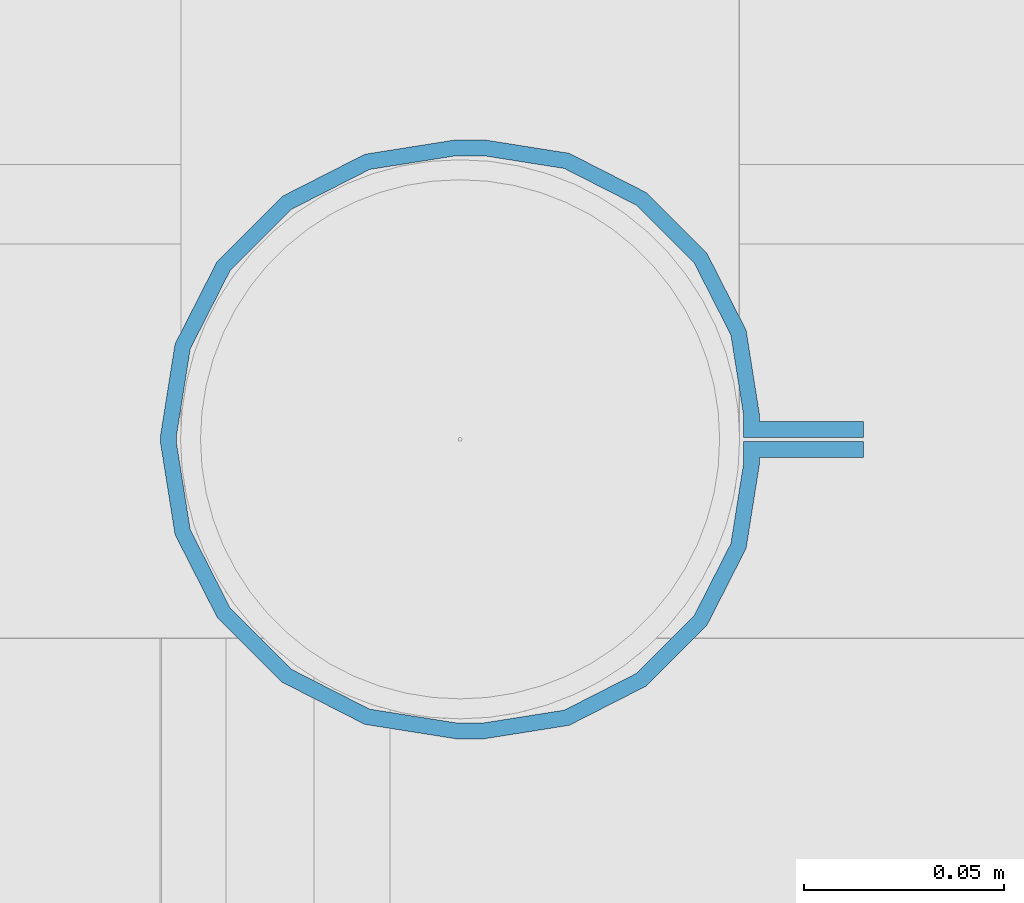
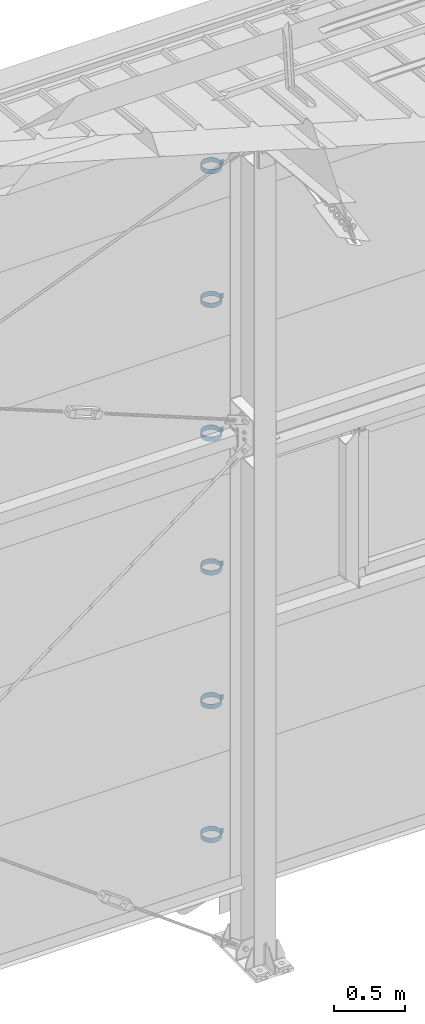
# One storey, part 309 of 709: 6 beams, 6 elements without a shape of their own.
"""IFC4 building model written with IfcOpenShell, lengths in millimetres."""

import ifcopenshell
import ifcopenshell.guid

model = None  # the IFC model being written
_history = None  # IfcOwnerHistory: only IFC2X3 demands one
_inside = {}  # id of a spatial element -> (the spatial element, [elements in it])
_under = {}  # id of a project, library or spatial element -> (it, [spatial elements below it])
_declared = {}  # id of a project -> (the project, [libraries it declares])
_typed = {}  # id of a type object -> (the type object, [elements of that type])
_made_of = {}  # id of a material, layer set ... -> (it, [elements and type objects made of it])


def new_model(schema):
    """Start an empty IFC model of exactly this schema.

    Asked for "IFC4X3", IfcOpenShell would pick the latest addendum, in which some entities
    have other attributes; the version numbers below select the first issue.
    IFC2X3 requires an IfcOwnerHistory on every rooted entity: one is made here for all.
    """
    global model, _history
    if schema == "IFC4X3":
        model = ifcopenshell.file(schema_version=(4, 3, 0, 0))
    else:
        model = ifcopenshell.file(schema=schema)
    _inside.clear()
    _under.clear()
    _declared.clear()
    _typed.clear()
    _made_of.clear()
    _history = None
    if model.schema == "IFC2X3":
        org = make("IfcOrganization", Name="unknown")
        user = make(
            "IfcPersonAndOrganization",
            ThePerson=make("IfcPerson", FamilyName="unknown"),
            TheOrganization=org,
        )
        app = make(
            "IfcApplication",
            ApplicationDeveloper=org,
            Version="unknown",
            ApplicationFullName="unknown",
            ApplicationIdentifier="unknown",
        )
        _history = make(
            "IfcOwnerHistory",
            OwningUser=user,
            OwningApplication=app,
            ChangeAction="ADDED",
            CreationDate=0,
        )
    return model


def make(cls, **values):
    """One entity of the class cls with the attributes given. An attribute that is None is left unset."""
    return model.create_entity(
        cls, **{name: value for name, value in values.items() if value is not None}
    )


def rooted(cls, **values):
    """An entity with a GlobalId (a new one), such as an element, a storey or a relation."""
    return make(cls, GlobalId=ifcopenshell.guid.new(), OwnerHistory=_history, **values)


def si_unit(unit_type, name, prefix=None):
    """IfcSIUnit, for example si_unit("LENGTHUNIT", "METRE", prefix="MILLI")."""
    return make("IfcSIUnit", UnitType=unit_type, Prefix=prefix, Name=name)


def assignment(units):
    """IfcUnitAssignment: the units of a project."""
    return None if units is None else make("IfcUnitAssignment", Units=units)


def point(xyz):
    """IfcCartesianPoint."""
    return None if xyz is None else make("IfcCartesianPoint", Coordinates=xyz)


def direction(xyz):
    """IfcDirection."""
    return None if xyz is None else make("IfcDirection", DirectionRatios=xyz)


def frame(location, z_axis=None, x_axis=None):
    """IfcAxis2Placement3D, a coordinate frame: its origin and axes. An axis left out is left unset."""
    return make(
        "IfcAxis2Placement3D",
        Location=point(location),
        Axis=direction(z_axis),
        RefDirection=direction(x_axis),
    )


def origin_with_axes():
    """The frame at (0, 0, 0) with the z axis (0, 0, 1) and the x axis (1, 0, 0) written out."""
    return frame((0.0, 0.0, 0.0), z_axis=(0.0, 0.0, 1.0), x_axis=(1.0, 0.0, 0.0))


def place(relative_to, where):
    """IfcLocalPlacement: puts the frame where relative to a parent placement (None: the world)."""
    return make(
        "IfcLocalPlacement", PlacementRelTo=relative_to, RelativePlacement=where
    )


def context(
    kind, dimensions, precision=None, world=None, true_north=None, identifier=None
):
    """IfcGeometricRepresentationContext, for example the 3D "Model" context."""
    return make(
        "IfcGeometricRepresentationContext",
        ContextIdentifier=identifier,
        ContextType=kind,
        CoordinateSpaceDimension=dimensions,
        Precision=precision,
        WorldCoordinateSystem=world,
        TrueNorth=true_north,
    )


def subcontext(parent, identifier, kind, view, scale=None):
    """IfcGeometricRepresentationSubContext, for example "Body" below "Model"."""
    return make(
        "IfcGeometricRepresentationSubContext",
        ContextIdentifier=identifier,
        ContextType=kind,
        ParentContext=parent,
        TargetScale=scale,
        TargetView=view,
    )


def project(units=None, contexts=None):
    """IfcProject with its units and contexts."""
    return rooted(
        "IfcProject",
        Name="project",
        RepresentationContexts=contexts,
        UnitsInContext=assignment(units),
    )


def spatial(cls, under=None, at=None, **own):
    """A site, building, storey or space (cls), placed at a placement, below another one or the project."""
    s = rooted(cls, ObjectPlacement=at, **own)
    if under is not None:
        _under.setdefault(under.id(), (under, []))[1].append(s)
    return s


def point_list(points):
    """IfcCartesianPointList2D or 3D."""
    cls = (
        "IfcCartesianPointList2D" if len(points[0]) == 2 else "IfcCartesianPointList3D"
    )
    return make(cls, CoordList=points)


def polygons(points, faces, closed=None, point_numbers=None):
    """IfcPolygonalFaceSet: a face is its outer loop, then its inner loops; points numbered from 1."""
    made = []
    for loops in faces:
        if len(loops) == 1:
            made.append(make("IfcIndexedPolygonalFace", CoordIndex=loops[0]))
        else:
            made.append(
                make(
                    "IfcIndexedPolygonalFaceWithVoids",
                    CoordIndex=loops[0],
                    InnerCoordIndices=loops[1:],
                )
            )
    return make(
        "IfcPolygonalFaceSet",
        Coordinates=point_list(points),
        Closed=closed,
        Faces=made,
        PnIndex=point_numbers,
    )


def shape(context_of_items, identifier, shape_type, items):
    """IfcShapeRepresentation: the items that make up one representation, for example the "Body"."""
    return make(
        "IfcShapeRepresentation",
        ContextOfItems=context_of_items,
        RepresentationIdentifier=identifier,
        RepresentationType=shape_type,
        Items=items,
    )


def material(Name=None, Category=None):
    """IfcMaterial."""
    return make("IfcMaterial", Name=Name, Category=Category)


def made_of(thing, what):
    """Note that an element or type object is made of a material, layer set ...; save() writes the relation."""
    if what is not None:
        _made_of.setdefault(what.id(), (what, []))[1].append(thing)
    return thing


def element(
    cls,
    number,
    at=None,
    inside=None,
    cuts=None,
    type_object=None,
    material=None,
    context=None,
    identifier="Body",
    shape_type=None,
    held_by="IfcProductDefinitionShape",
    body=None,
    shapes=None,
    **own,
):
    """One element of the class cls, such as IfcWall. Its Tag is "e" and its number.

    at: its placement. inside: the storey or other place that contains it. cuts: it is an
    opening in that element (IfcRelVoidsElement). A single representation is given by context,
    identifier, shape_type and body (its items); several are given by shapes. held_by: the class
    of the entity that holds the representations. save() writes the other relations.
    """
    e = rooted(cls, Tag="e%d" % number, ObjectPlacement=at, **own)
    if body is not None:
        shapes = [shape(context, identifier, shape_type, body)]
    if shapes is not None:
        e.Representation = make(held_by, Representations=shapes)
    if inside is not None:
        _inside.setdefault(inside.id(), (inside, []))[1].append(e)
    if cuts is not None:
        rooted(
            "IfcRelVoidsElement", RelatingBuildingElement=cuts, RelatedOpeningElement=e
        )
    if type_object is not None:
        _typed.setdefault(type_object.id(), (type_object, []))[1].append(e)
    return made_of(e, material)


def aggregate(whole, parts):
    """IfcRelAggregates: a whole, such as a stair, and the parts it consists of."""
    return rooted("IfcRelAggregates", RelatingObject=whole, RelatedObjects=parts)


def save(model, path):
    """Write the relations noted so far, then the file.

    IfcRelAggregates (storeys below a building ...), IfcRelContainedInSpatialStructure (elements
    in a storey), IfcRelDefinesByType, IfcRelAssociatesMaterial and IfcRelDeclares: one each for
    every whole, place, type object, material and project.
    """
    for whole, parts in _under.values():
        aggregate(whole, parts)
    for where, things in _inside.values():
        rooted(
            "IfcRelContainedInSpatialStructure",
            RelatedElements=things,
            RelatingStructure=where,
        )
    for kind, things in _typed.values():
        rooted("IfcRelDefinesByType", RelatedObjects=things, RelatingType=kind)
    for what, things in _made_of.values():
        rooted("IfcRelAssociatesMaterial", RelatedObjects=things, RelatingMaterial=what)
    for by, libraries in _declared.values():
        rooted("IfcRelDeclares", RelatingContext=by, RelatedDefinitions=libraries)
    model.write(path)


model = new_model("IFC4")

# Units and contexts
model_context = context("Model", 3, precision=0.2, world=origin_with_axes(), true_north=direction((0.0, 1.0)))
body_context = subcontext(model_context, "Body", "Model", "MODEL_VIEW")
ifc_project = project(units=[si_unit("LENGTHUNIT", "METRE", prefix="MILLI"), si_unit("AREAUNIT", "SQUARE_METRE"), si_unit("VOLUMEUNIT", "CUBIC_METRE"), si_unit("MASSUNIT", "GRAM", prefix="KILO"), si_unit("TIMEUNIT", "SECOND"), si_unit("PLANEANGLEUNIT", "RADIAN"), si_unit("SOLIDANGLEUNIT", "STERADIAN"), si_unit("THERMODYNAMICTEMPERATUREUNIT", "DEGREE_CELSIUS"), si_unit("LUMINOUSINTENSITYUNIT", "LUMEN")], contexts=[model_context])

# Site, building, storey
site_placement = place(None, origin_with_axes())
site = spatial("IfcSite", under=ifc_project, at=site_placement, CompositionType="ELEMENT")
building_placement = place(site_placement, origin_with_axes())
building = spatial("IfcBuilding", under=site, at=building_placement, Name="Undefined", CompositionType="ELEMENT")
storey_placement = place(building_placement, origin_with_axes())
storey = spatial("IfcBuildingStorey", under=building, at=storey_placement, Name="Undefined", CompositionType="ELEMENT", Elevation=0.0)

# Assembly, beam
assembly_1_placement = place(storey_placement, frame((28101.0, 22422.5, 6226.92297), z_axis=(0.0, 1.0, 0.0), x_axis=(-1.0, 0.0, 0.0)))
assembly_1 = element("IfcElementAssembly", 1, at=assembly_1_placement, inside=storey)
ifc_material = material(Name="Steel_Undefined", Category="STEEL")
beam_1_placement = place(assembly_1_placement, origin_with_axes())
beam_1 = element("IfcBeam", 2, at=beam_1_placement, material=ifc_material, ObjectType="616", context=body_context, shape_type="Tessellation", body=[
    polygons([(0.0, -20.0, 2.0), (0.0, 20.0, 2.0), (0.0, 20.0, -2.0), (0.0, -20.0, -2.0), (30.0, 20.0, -2.0), (30.0, -20.0, -2.0), (26.0, -20.0, 2.0), (26.0, 20.0, 2.0), (30.0, 20.0, 3.5), (30.0, -20.0, 3.5), (26.0, -20.0, 3.5), (26.0, 20.0, 3.5), (33.18133, 20.0, 23.5861), (33.18133, -20.0, 23.5861), (29.3771, -20.0, 24.82217), (29.3771, 20.0, 24.82217), (39.17783, -20.0, 44.05718), (39.17783, 20.0, 44.05718), (42.4139, 20.0, 41.70604), (42.4139, -20.0, 41.70604), (54.44282, -20.0, 59.32217), (54.44282, 20.0, 59.32217), (56.79396, 20.0, 56.0861), (56.79396, -20.0, 56.0861), (73.67783, -20.0, 69.1229), (73.67783, 20.0, 69.1229), (74.9139, 20.0, 65.31867), (74.9139, -20.0, 65.31867), (95.0, -20.0, 72.5), (95.0, 20.0, 72.5), (95.0, 20.0, 68.5), (95.0, -20.0, 68.5), (102.0, 20.0, 68.5), (102.0, -20.0, 68.5), (102.0, -20.0, 72.5), (102.0, 20.0, 72.5), (123.63119, 20.0, 65.07396), (123.63119, -20.0, 65.07396), (124.86726, -20.0, 68.87818), (124.86726, 20.0, 68.87818), (145.49611, -20.0, 58.36726), (145.49611, 20.0, 58.36726), (143.14497, 20.0, 55.13119), (143.14497, -20.0, 55.13119), (161.86726, -20.0, 41.99611), (161.86726, 20.0, 41.99611), (158.63119, 20.0, 39.64497), (158.63119, -20.0, 39.64497), (172.37818, -20.0, 21.36726), (172.37818, 20.0, 21.36726), (168.57396, 20.0, 20.13119), (168.57396, -20.0, 20.13119), (176.0, -20.0, -1.5), (176.0, 20.0, -1.5), (172.0, 20.0, -1.5), (172.0, -20.0, -1.5), (172.0, 20.0, -3.5), (172.0, -20.0, -3.5), (176.0, -20.0, -3.5), (176.0, 20.0, -3.5), (168.57396, 20.0, -25.13119), (168.57396, -20.0, -25.13119), (172.37818, -20.0, -26.36726), (172.37818, 20.0, -26.36726), (161.86726, -20.0, -46.99611), (161.86726, 20.0, -46.99611), (158.63119, 20.0, -44.64497), (158.63119, -20.0, -44.64497), (145.49611, -20.0, -63.36726), (145.49611, 20.0, -63.36726), (143.14497, 20.0, -60.13119), (143.14497, -20.0, -60.13119), (124.86726, -20.0, -73.87818), (124.86726, 20.0, -73.87818), (123.63119, 20.0, -70.07396), (123.63119, -20.0, -70.07396), (102.0, -20.0, -77.5), (102.0, 20.0, -77.5), (102.0, 20.0, -73.5), (102.0, -20.0, -73.5), (95.0, 20.0, -73.5), (95.0, -20.0, -73.5), (95.0, -20.0, -77.5), (95.0, 20.0, -77.5), (74.9139, 20.0, -70.31867), (74.9139, -20.0, -70.31867), (73.67783, -20.0, -74.1229), (73.67783, 20.0, -74.1229), (54.44282, -20.0, -64.32217), (54.44282, 20.0, -64.32217), (56.79396, 20.0, -61.0861), (56.79396, -20.0, -61.0861), (39.17783, -20.0, -49.05718), (39.17783, 20.0, -49.05718), (42.4139, 20.0, -46.70604), (42.4139, -20.0, -46.70604), (29.3771, -20.0, -29.82217), (29.3771, 20.0, -29.82217), (33.18133, 20.0, -28.5861), (33.18133, -20.0, -28.5861), (26.0, -20.0, -8.5), (26.0, 20.0, -8.5), (30.0, 20.0, -8.5), (30.0, -20.0, -8.5), (30.0, 20.0, -3.0), (30.0, -20.0, -3.0), (26.0, -20.0, -7.0), (26.0, 20.0, -7.0), (0.0, 20.0, -3.0), (0.0, -20.0, -3.0), (0.0, 20.0, -7.0), (0.0, -20.0, -7.0)], [[[1, 2, 3, 4]], [[4, 3, 5, 6]], [[2, 1, 7, 8]], [[6, 5, 9, 10]], [[8, 7, 11, 12]], [[10, 9, 13, 14]], [[12, 11, 15, 16]], [[15, 17, 18, 16]], [[13, 19, 20, 14]], [[17, 21, 22, 18]], [[19, 23, 24, 20]], [[21, 25, 26, 22]], [[23, 27, 28, 24]], [[25, 29, 30, 26]], [[27, 31, 32, 28]], [[32, 31, 33, 34]], [[30, 29, 35, 36]], [[34, 33, 37, 38]], [[36, 35, 39, 40]], [[39, 41, 42, 40]], [[37, 43, 44, 38]], [[41, 45, 46, 42]], [[43, 47, 48, 44]], [[45, 49, 50, 46]], [[47, 51, 52, 48]], [[49, 53, 54, 50]], [[51, 55, 56, 52]], [[56, 55, 57, 58]], [[54, 53, 59, 60]], [[58, 57, 61, 62]], [[60, 59, 63, 64]], [[63, 65, 66, 64]], [[61, 67, 68, 62]], [[65, 69, 70, 66]], [[67, 71, 72, 68]], [[69, 73, 74, 70]], [[71, 75, 76, 72]], [[73, 77, 78, 74]], [[75, 79, 80, 76]], [[80, 79, 81, 82]], [[78, 77, 83, 84]], [[82, 81, 85, 86]], [[84, 83, 87, 88]], [[87, 89, 90, 88]], [[85, 91, 92, 86]], [[89, 93, 94, 90]], [[91, 95, 96, 92]], [[93, 97, 98, 94]], [[95, 99, 100, 96]], [[97, 101, 102, 98]], [[99, 103, 104, 100]], [[104, 103, 105, 106]], [[102, 101, 107, 108]], [[106, 105, 109, 110]], [[105, 103, 99, 95, 91, 85, 81, 79, 75, 71, 67, 61, 57, 55, 51, 47, 43, 37, 33, 31, 27, 23, 19, 13, 9, 5, 3, 2, 8, 12, 16, 18, 22, 26, 30, 36, 40, 42, 46, 50, 54, 60, 64, 66, 70, 74, 78, 84, 88, 90, 94, 98, 102, 108, 111, 109]], [[108, 107, 112, 111]], [[107, 101, 97, 93, 89, 87, 83, 77, 73, 69, 65, 63, 59, 53, 49, 45, 41, 39, 35, 29, 25, 21, 17, 15, 11, 7, 1, 4, 6, 10, 14, 20, 24, 28, 32, 34, 38, 44, 48, 52, 56, 58, 62, 68, 72, 76, 80, 82, 86, 92, 96, 100, 104, 106, 110, 112]], [[111, 112, 110, 109]]], closed=True),
])
aggregate(assembly_1, [beam_1])

assembly_2_placement = place(storey_placement, frame((28101.0, 22422.5, 5076.92297), z_axis=(0.0, 1.0, 0.0), x_axis=(-1.0, 0.0, 0.0)))
assembly_2 = element("IfcElementAssembly", 3, at=assembly_2_placement, inside=storey)
beam_2_placement = place(assembly_2_placement, origin_with_axes())
beam_2 = element("IfcBeam", 4, at=beam_2_placement, material=ifc_material, ObjectType="616", context=body_context, shape_type="Tessellation", body=[
    polygons([(0.0, -20.0, 2.0), (0.0, 20.0, 2.0), (0.0, 20.0, -2.0), (0.0, -20.0, -2.0), (30.0, 20.0, -2.0), (30.0, -20.0, -2.0), (26.0, -20.0, 2.0), (26.0, 20.0, 2.0), (30.0, 20.0, 3.5), (30.0, -20.0, 3.5), (26.0, -20.0, 3.5), (26.0, 20.0, 3.5), (33.18133, 20.0, 23.5861), (33.18133, -20.0, 23.5861), (29.3771, -20.0, 24.82217), (29.3771, 20.0, 24.82217), (39.17783, -20.0, 44.05718), (39.17783, 20.0, 44.05718), (42.4139, 20.0, 41.70604), (42.4139, -20.0, 41.70604), (54.44282, -20.0, 59.32217), (54.44282, 20.0, 59.32217), (56.79396, 20.0, 56.0861), (56.79396, -20.0, 56.0861), (73.67783, -20.0, 69.1229), (73.67783, 20.0, 69.1229), (74.9139, 20.0, 65.31867), (74.9139, -20.0, 65.31867), (95.0, -20.0, 72.5), (95.0, 20.0, 72.5), (95.0, 20.0, 68.5), (95.0, -20.0, 68.5), (102.0, 20.0, 68.5), (102.0, -20.0, 68.5), (102.0, -20.0, 72.5), (102.0, 20.0, 72.5), (123.63119, 20.0, 65.07396), (123.63119, -20.0, 65.07396), (124.86726, -20.0, 68.87818), (124.86726, 20.0, 68.87818), (145.49611, -20.0, 58.36726), (145.49611, 20.0, 58.36726), (143.14497, 20.0, 55.13119), (143.14497, -20.0, 55.13119), (161.86726, -20.0, 41.99611), (161.86726, 20.0, 41.99611), (158.63119, 20.0, 39.64497), (158.63119, -20.0, 39.64497), (172.37818, -20.0, 21.36726), (172.37818, 20.0, 21.36726), (168.57396, 20.0, 20.13119), (168.57396, -20.0, 20.13119), (176.0, -20.0, -1.5), (176.0, 20.0, -1.5), (172.0, 20.0, -1.5), (172.0, -20.0, -1.5), (172.0, 20.0, -3.5), (172.0, -20.0, -3.5), (176.0, -20.0, -3.5), (176.0, 20.0, -3.5), (168.57396, 20.0, -25.13119), (168.57396, -20.0, -25.13119), (172.37818, -20.0, -26.36726), (172.37818, 20.0, -26.36726), (161.86726, -20.0, -46.99611), (161.86726, 20.0, -46.99611), (158.63119, 20.0, -44.64497), (158.63119, -20.0, -44.64497), (145.49611, -20.0, -63.36726), (145.49611, 20.0, -63.36726), (143.14497, 20.0, -60.13119), (143.14497, -20.0, -60.13119), (124.86726, -20.0, -73.87818), (124.86726, 20.0, -73.87818), (123.63119, 20.0, -70.07396), (123.63119, -20.0, -70.07396), (102.0, -20.0, -77.5), (102.0, 20.0, -77.5), (102.0, 20.0, -73.5), (102.0, -20.0, -73.5), (95.0, 20.0, -73.5), (95.0, -20.0, -73.5), (95.0, -20.0, -77.5), (95.0, 20.0, -77.5), (74.9139, 20.0, -70.31867), (74.9139, -20.0, -70.31867), (73.67783, -20.0, -74.1229), (73.67783, 20.0, -74.1229), (54.44282, -20.0, -64.32217), (54.44282, 20.0, -64.32217), (56.79396, 20.0, -61.0861), (56.79396, -20.0, -61.0861), (39.17783, -20.0, -49.05718), (39.17783, 20.0, -49.05718), (42.4139, 20.0, -46.70604), (42.4139, -20.0, -46.70604), (29.3771, -20.0, -29.82217), (29.3771, 20.0, -29.82217), (33.18133, 20.0, -28.5861), (33.18133, -20.0, -28.5861), (26.0, -20.0, -8.5), (26.0, 20.0, -8.5), (30.0, 20.0, -8.5), (30.0, -20.0, -8.5), (30.0, 20.0, -3.0), (30.0, -20.0, -3.0), (26.0, -20.0, -7.0), (26.0, 20.0, -7.0), (0.0, 20.0, -3.0), (0.0, -20.0, -3.0), (0.0, 20.0, -7.0), (0.0, -20.0, -7.0)], [[[1, 2, 3, 4]], [[4, 3, 5, 6]], [[2, 1, 7, 8]], [[6, 5, 9, 10]], [[8, 7, 11, 12]], [[10, 9, 13, 14]], [[12, 11, 15, 16]], [[15, 17, 18, 16]], [[13, 19, 20, 14]], [[17, 21, 22, 18]], [[19, 23, 24, 20]], [[21, 25, 26, 22]], [[23, 27, 28, 24]], [[25, 29, 30, 26]], [[27, 31, 32, 28]], [[32, 31, 33, 34]], [[30, 29, 35, 36]], [[34, 33, 37, 38]], [[36, 35, 39, 40]], [[39, 41, 42, 40]], [[37, 43, 44, 38]], [[41, 45, 46, 42]], [[43, 47, 48, 44]], [[45, 49, 50, 46]], [[47, 51, 52, 48]], [[49, 53, 54, 50]], [[51, 55, 56, 52]], [[56, 55, 57, 58]], [[54, 53, 59, 60]], [[58, 57, 61, 62]], [[60, 59, 63, 64]], [[63, 65, 66, 64]], [[61, 67, 68, 62]], [[65, 69, 70, 66]], [[67, 71, 72, 68]], [[69, 73, 74, 70]], [[71, 75, 76, 72]], [[73, 77, 78, 74]], [[75, 79, 80, 76]], [[80, 79, 81, 82]], [[78, 77, 83, 84]], [[82, 81, 85, 86]], [[84, 83, 87, 88]], [[87, 89, 90, 88]], [[85, 91, 92, 86]], [[89, 93, 94, 90]], [[91, 95, 96, 92]], [[93, 97, 98, 94]], [[95, 99, 100, 96]], [[97, 101, 102, 98]], [[99, 103, 104, 100]], [[104, 103, 105, 106]], [[102, 101, 107, 108]], [[106, 105, 109, 110]], [[105, 103, 99, 95, 91, 85, 81, 79, 75, 71, 67, 61, 57, 55, 51, 47, 43, 37, 33, 31, 27, 23, 19, 13, 9, 5, 3, 2, 8, 12, 16, 18, 22, 26, 30, 36, 40, 42, 46, 50, 54, 60, 64, 66, 70, 74, 78, 84, 88, 90, 94, 98, 102, 108, 111, 109]], [[108, 107, 112, 111]], [[107, 101, 97, 93, 89, 87, 83, 77, 73, 69, 65, 63, 59, 53, 49, 45, 41, 39, 35, 29, 25, 21, 17, 15, 11, 7, 1, 4, 6, 10, 14, 20, 24, 28, 32, 34, 38, 44, 48, 52, 56, 58, 62, 68, 72, 76, 80, 82, 86, 92, 96, 100, 104, 106, 110, 112]], [[111, 112, 110, 109]]], closed=True),
])
aggregate(assembly_2, [beam_2])

assembly_3_placement = place(storey_placement, frame((28101.0, 22422.5, 3926.92297), z_axis=(0.0, 1.0, 0.0), x_axis=(-1.0, 0.0, 0.0)))
assembly_3 = element("IfcElementAssembly", 5, at=assembly_3_placement, inside=storey)
beam_3_placement = place(assembly_3_placement, origin_with_axes())
beam_3 = element("IfcBeam", 6, at=beam_3_placement, material=ifc_material, ObjectType="616", context=body_context, shape_type="Tessellation", body=[
    polygons([(0.0, -20.0, 2.0), (0.0, 20.0, 2.0), (0.0, 20.0, -2.0), (0.0, -20.0, -2.0), (30.0, 20.0, -2.0), (30.0, -20.0, -2.0), (26.0, -20.0, 2.0), (26.0, 20.0, 2.0), (30.0, 20.0, 3.5), (30.0, -20.0, 3.5), (26.0, -20.0, 3.5), (26.0, 20.0, 3.5), (33.18133, 20.0, 23.5861), (33.18133, -20.0, 23.5861), (29.3771, -20.0, 24.82217), (29.3771, 20.0, 24.82217), (39.17783, -20.0, 44.05718), (39.17783, 20.0, 44.05718), (42.4139, 20.0, 41.70604), (42.4139, -20.0, 41.70604), (54.44282, -20.0, 59.32217), (54.44282, 20.0, 59.32217), (56.79396, 20.0, 56.0861), (56.79396, -20.0, 56.0861), (73.67783, -20.0, 69.1229), (73.67783, 20.0, 69.1229), (74.9139, 20.0, 65.31867), (74.9139, -20.0, 65.31867), (95.0, -20.0, 72.5), (95.0, 20.0, 72.5), (95.0, 20.0, 68.5), (95.0, -20.0, 68.5), (102.0, 20.0, 68.5), (102.0, -20.0, 68.5), (102.0, -20.0, 72.5), (102.0, 20.0, 72.5), (123.63119, 20.0, 65.07396), (123.63119, -20.0, 65.07396), (124.86726, -20.0, 68.87818), (124.86726, 20.0, 68.87818), (145.49611, -20.0, 58.36726), (145.49611, 20.0, 58.36726), (143.14497, 20.0, 55.13119), (143.14497, -20.0, 55.13119), (161.86726, -20.0, 41.99611), (161.86726, 20.0, 41.99611), (158.63119, 20.0, 39.64497), (158.63119, -20.0, 39.64497), (172.37818, -20.0, 21.36726), (172.37818, 20.0, 21.36726), (168.57396, 20.0, 20.13119), (168.57396, -20.0, 20.13119), (176.0, -20.0, -1.5), (176.0, 20.0, -1.5), (172.0, 20.0, -1.5), (172.0, -20.0, -1.5), (172.0, 20.0, -3.5), (172.0, -20.0, -3.5), (176.0, -20.0, -3.5), (176.0, 20.0, -3.5), (168.57396, 20.0, -25.13119), (168.57396, -20.0, -25.13119), (172.37818, -20.0, -26.36726), (172.37818, 20.0, -26.36726), (161.86726, -20.0, -46.99611), (161.86726, 20.0, -46.99611), (158.63119, 20.0, -44.64497), (158.63119, -20.0, -44.64497), (145.49611, -20.0, -63.36726), (145.49611, 20.0, -63.36726), (143.14497, 20.0, -60.13119), (143.14497, -20.0, -60.13119), (124.86726, -20.0, -73.87818), (124.86726, 20.0, -73.87818), (123.63119, 20.0, -70.07396), (123.63119, -20.0, -70.07396), (102.0, -20.0, -77.5), (102.0, 20.0, -77.5), (102.0, 20.0, -73.5), (102.0, -20.0, -73.5), (95.0, 20.0, -73.5), (95.0, -20.0, -73.5), (95.0, -20.0, -77.5), (95.0, 20.0, -77.5), (74.9139, 20.0, -70.31867), (74.9139, -20.0, -70.31867), (73.67783, -20.0, -74.1229), (73.67783, 20.0, -74.1229), (54.44282, -20.0, -64.32217), (54.44282, 20.0, -64.32217), (56.79396, 20.0, -61.0861), (56.79396, -20.0, -61.0861), (39.17783, -20.0, -49.05718), (39.17783, 20.0, -49.05718), (42.4139, 20.0, -46.70604), (42.4139, -20.0, -46.70604), (29.3771, -20.0, -29.82217), (29.3771, 20.0, -29.82217), (33.18133, 20.0, -28.5861), (33.18133, -20.0, -28.5861), (26.0, -20.0, -8.5), (26.0, 20.0, -8.5), (30.0, 20.0, -8.5), (30.0, -20.0, -8.5), (30.0, 20.0, -3.0), (30.0, -20.0, -3.0), (26.0, -20.0, -7.0), (26.0, 20.0, -7.0), (0.0, 20.0, -3.0), (0.0, -20.0, -3.0), (0.0, 20.0, -7.0), (0.0, -20.0, -7.0)], [[[1, 2, 3, 4]], [[4, 3, 5, 6]], [[2, 1, 7, 8]], [[6, 5, 9, 10]], [[8, 7, 11, 12]], [[10, 9, 13, 14]], [[12, 11, 15, 16]], [[15, 17, 18, 16]], [[13, 19, 20, 14]], [[17, 21, 22, 18]], [[19, 23, 24, 20]], [[21, 25, 26, 22]], [[23, 27, 28, 24]], [[25, 29, 30, 26]], [[27, 31, 32, 28]], [[32, 31, 33, 34]], [[30, 29, 35, 36]], [[34, 33, 37, 38]], [[36, 35, 39, 40]], [[39, 41, 42, 40]], [[37, 43, 44, 38]], [[41, 45, 46, 42]], [[43, 47, 48, 44]], [[45, 49, 50, 46]], [[47, 51, 52, 48]], [[49, 53, 54, 50]], [[51, 55, 56, 52]], [[56, 55, 57, 58]], [[54, 53, 59, 60]], [[58, 57, 61, 62]], [[60, 59, 63, 64]], [[63, 65, 66, 64]], [[61, 67, 68, 62]], [[65, 69, 70, 66]], [[67, 71, 72, 68]], [[69, 73, 74, 70]], [[71, 75, 76, 72]], [[73, 77, 78, 74]], [[75, 79, 80, 76]], [[80, 79, 81, 82]], [[78, 77, 83, 84]], [[82, 81, 85, 86]], [[84, 83, 87, 88]], [[87, 89, 90, 88]], [[85, 91, 92, 86]], [[89, 93, 94, 90]], [[91, 95, 96, 92]], [[93, 97, 98, 94]], [[95, 99, 100, 96]], [[97, 101, 102, 98]], [[99, 103, 104, 100]], [[104, 103, 105, 106]], [[102, 101, 107, 108]], [[106, 105, 109, 110]], [[105, 103, 99, 95, 91, 85, 81, 79, 75, 71, 67, 61, 57, 55, 51, 47, 43, 37, 33, 31, 27, 23, 19, 13, 9, 5, 3, 2, 8, 12, 16, 18, 22, 26, 30, 36, 40, 42, 46, 50, 54, 60, 64, 66, 70, 74, 78, 84, 88, 90, 94, 98, 102, 108, 111, 109]], [[108, 107, 112, 111]], [[107, 101, 97, 93, 89, 87, 83, 77, 73, 69, 65, 63, 59, 53, 49, 45, 41, 39, 35, 29, 25, 21, 17, 15, 11, 7, 1, 4, 6, 10, 14, 20, 24, 28, 32, 34, 38, 44, 48, 52, 56, 58, 62, 68, 72, 76, 80, 82, 86, 92, 96, 100, 104, 106, 110, 112]], [[111, 112, 110, 109]]], closed=True),
])
aggregate(assembly_3, [beam_3])

assembly_4_placement = place(storey_placement, frame((28101.0, 22422.5, 2776.92297), z_axis=(0.0, 1.0, 0.0), x_axis=(-1.0, 0.0, 0.0)))
assembly_4 = element("IfcElementAssembly", 7, at=assembly_4_placement, inside=storey)
beam_4_placement = place(assembly_4_placement, origin_with_axes())
beam_4 = element("IfcBeam", 8, at=beam_4_placement, material=ifc_material, ObjectType="616", context=body_context, shape_type="Tessellation", body=[
    polygons([(0.0, -20.0, 2.0), (0.0, 20.0, 2.0), (0.0, 20.0, -2.0), (0.0, -20.0, -2.0), (30.0, 20.0, -2.0), (30.0, -20.0, -2.0), (26.0, -20.0, 2.0), (26.0, 20.0, 2.0), (30.0, 20.0, 3.5), (30.0, -20.0, 3.5), (26.0, -20.0, 3.5), (26.0, 20.0, 3.5), (33.18133, 20.0, 23.5861), (33.18133, -20.0, 23.5861), (29.3771, -20.0, 24.82217), (29.3771, 20.0, 24.82217), (39.17783, -20.0, 44.05718), (39.17783, 20.0, 44.05718), (42.4139, 20.0, 41.70604), (42.4139, -20.0, 41.70604), (54.44282, -20.0, 59.32217), (54.44282, 20.0, 59.32217), (56.79396, 20.0, 56.0861), (56.79396, -20.0, 56.0861), (73.67783, -20.0, 69.1229), (73.67783, 20.0, 69.1229), (74.9139, 20.0, 65.31867), (74.9139, -20.0, 65.31867), (95.0, -20.0, 72.5), (95.0, 20.0, 72.5), (95.0, 20.0, 68.5), (95.0, -20.0, 68.5), (102.0, 20.0, 68.5), (102.0, -20.0, 68.5), (102.0, -20.0, 72.5), (102.0, 20.0, 72.5), (123.63119, 20.0, 65.07396), (123.63119, -20.0, 65.07396), (124.86726, -20.0, 68.87818), (124.86726, 20.0, 68.87818), (145.49611, -20.0, 58.36726), (145.49611, 20.0, 58.36726), (143.14497, 20.0, 55.13119), (143.14497, -20.0, 55.13119), (161.86726, -20.0, 41.99611), (161.86726, 20.0, 41.99611), (158.63119, 20.0, 39.64497), (158.63119, -20.0, 39.64497), (172.37818, -20.0, 21.36726), (172.37818, 20.0, 21.36726), (168.57396, 20.0, 20.13119), (168.57396, -20.0, 20.13119), (176.0, -20.0, -1.5), (176.0, 20.0, -1.5), (172.0, 20.0, -1.5), (172.0, -20.0, -1.5), (172.0, 20.0, -3.5), (172.0, -20.0, -3.5), (176.0, -20.0, -3.5), (176.0, 20.0, -3.5), (168.57396, 20.0, -25.13119), (168.57396, -20.0, -25.13119), (172.37818, -20.0, -26.36726), (172.37818, 20.0, -26.36726), (161.86726, -20.0, -46.99611), (161.86726, 20.0, -46.99611), (158.63119, 20.0, -44.64497), (158.63119, -20.0, -44.64497), (145.49611, -20.0, -63.36726), (145.49611, 20.0, -63.36726), (143.14497, 20.0, -60.13119), (143.14497, -20.0, -60.13119), (124.86726, -20.0, -73.87818), (124.86726, 20.0, -73.87818), (123.63119, 20.0, -70.07396), (123.63119, -20.0, -70.07396), (102.0, -20.0, -77.5), (102.0, 20.0, -77.5), (102.0, 20.0, -73.5), (102.0, -20.0, -73.5), (95.0, 20.0, -73.5), (95.0, -20.0, -73.5), (95.0, -20.0, -77.5), (95.0, 20.0, -77.5), (74.9139, 20.0, -70.31867), (74.9139, -20.0, -70.31867), (73.67783, -20.0, -74.1229), (73.67783, 20.0, -74.1229), (54.44282, -20.0, -64.32217), (54.44282, 20.0, -64.32217), (56.79396, 20.0, -61.0861), (56.79396, -20.0, -61.0861), (39.17783, -20.0, -49.05718), (39.17783, 20.0, -49.05718), (42.4139, 20.0, -46.70604), (42.4139, -20.0, -46.70604), (29.3771, -20.0, -29.82217), (29.3771, 20.0, -29.82217), (33.18133, 20.0, -28.5861), (33.18133, -20.0, -28.5861), (26.0, -20.0, -8.5), (26.0, 20.0, -8.5), (30.0, 20.0, -8.5), (30.0, -20.0, -8.5), (30.0, 20.0, -3.0), (30.0, -20.0, -3.0), (26.0, -20.0, -7.0), (26.0, 20.0, -7.0), (0.0, 20.0, -3.0), (0.0, -20.0, -3.0), (0.0, 20.0, -7.0), (0.0, -20.0, -7.0)], [[[1, 2, 3, 4]], [[4, 3, 5, 6]], [[2, 1, 7, 8]], [[6, 5, 9, 10]], [[8, 7, 11, 12]], [[10, 9, 13, 14]], [[12, 11, 15, 16]], [[15, 17, 18, 16]], [[13, 19, 20, 14]], [[17, 21, 22, 18]], [[19, 23, 24, 20]], [[21, 25, 26, 22]], [[23, 27, 28, 24]], [[25, 29, 30, 26]], [[27, 31, 32, 28]], [[32, 31, 33, 34]], [[30, 29, 35, 36]], [[34, 33, 37, 38]], [[36, 35, 39, 40]], [[39, 41, 42, 40]], [[37, 43, 44, 38]], [[41, 45, 46, 42]], [[43, 47, 48, 44]], [[45, 49, 50, 46]], [[47, 51, 52, 48]], [[49, 53, 54, 50]], [[51, 55, 56, 52]], [[56, 55, 57, 58]], [[54, 53, 59, 60]], [[58, 57, 61, 62]], [[60, 59, 63, 64]], [[63, 65, 66, 64]], [[61, 67, 68, 62]], [[65, 69, 70, 66]], [[67, 71, 72, 68]], [[69, 73, 74, 70]], [[71, 75, 76, 72]], [[73, 77, 78, 74]], [[75, 79, 80, 76]], [[80, 79, 81, 82]], [[78, 77, 83, 84]], [[82, 81, 85, 86]], [[84, 83, 87, 88]], [[87, 89, 90, 88]], [[85, 91, 92, 86]], [[89, 93, 94, 90]], [[91, 95, 96, 92]], [[93, 97, 98, 94]], [[95, 99, 100, 96]], [[97, 101, 102, 98]], [[99, 103, 104, 100]], [[104, 103, 105, 106]], [[102, 101, 107, 108]], [[106, 105, 109, 110]], [[105, 103, 99, 95, 91, 85, 81, 79, 75, 71, 67, 61, 57, 55, 51, 47, 43, 37, 33, 31, 27, 23, 19, 13, 9, 5, 3, 2, 8, 12, 16, 18, 22, 26, 30, 36, 40, 42, 46, 50, 54, 60, 64, 66, 70, 74, 78, 84, 88, 90, 94, 98, 102, 108, 111, 109]], [[108, 107, 112, 111]], [[107, 101, 97, 93, 89, 87, 83, 77, 73, 69, 65, 63, 59, 53, 49, 45, 41, 39, 35, 29, 25, 21, 17, 15, 11, 7, 1, 4, 6, 10, 14, 20, 24, 28, 32, 34, 38, 44, 48, 52, 56, 58, 62, 68, 72, 76, 80, 82, 86, 92, 96, 100, 104, 106, 110, 112]], [[111, 112, 110, 109]]], closed=True),
])
aggregate(assembly_4, [beam_4])

assembly_5_placement = place(storey_placement, frame((28101.0, 22422.5, 1626.92297), z_axis=(0.0, 1.0, 0.0), x_axis=(-1.0, 0.0, 0.0)))
assembly_5 = element("IfcElementAssembly", 9, at=assembly_5_placement, inside=storey)
beam_5_placement = place(assembly_5_placement, origin_with_axes())
beam_5 = element("IfcBeam", 10, at=beam_5_placement, material=ifc_material, ObjectType="616", context=body_context, shape_type="Tessellation", body=[
    polygons([(0.0, -20.0, 2.0), (0.0, 20.0, 2.0), (0.0, 20.0, -2.0), (0.0, -20.0, -2.0), (30.0, 20.0, -2.0), (30.0, -20.0, -2.0), (26.0, -20.0, 2.0), (26.0, 20.0, 2.0), (30.0, 20.0, 3.5), (30.0, -20.0, 3.5), (26.0, -20.0, 3.5), (26.0, 20.0, 3.5), (33.18133, 20.0, 23.5861), (33.18133, -20.0, 23.5861), (29.3771, -20.0, 24.82217), (29.3771, 20.0, 24.82217), (39.17783, -20.0, 44.05718), (39.17783, 20.0, 44.05718), (42.4139, 20.0, 41.70604), (42.4139, -20.0, 41.70604), (54.44282, -20.0, 59.32217), (54.44282, 20.0, 59.32217), (56.79396, 20.0, 56.0861), (56.79396, -20.0, 56.0861), (73.67783, -20.0, 69.1229), (73.67783, 20.0, 69.1229), (74.9139, 20.0, 65.31867), (74.9139, -20.0, 65.31867), (95.0, -20.0, 72.5), (95.0, 20.0, 72.5), (95.0, 20.0, 68.5), (95.0, -20.0, 68.5), (102.0, 20.0, 68.5), (102.0, -20.0, 68.5), (102.0, -20.0, 72.5), (102.0, 20.0, 72.5), (123.63119, 20.0, 65.07396), (123.63119, -20.0, 65.07396), (124.86726, -20.0, 68.87818), (124.86726, 20.0, 68.87818), (145.49611, -20.0, 58.36726), (145.49611, 20.0, 58.36726), (143.14497, 20.0, 55.13119), (143.14497, -20.0, 55.13119), (161.86726, -20.0, 41.99611), (161.86726, 20.0, 41.99611), (158.63119, 20.0, 39.64497), (158.63119, -20.0, 39.64497), (172.37818, -20.0, 21.36726), (172.37818, 20.0, 21.36726), (168.57396, 20.0, 20.13119), (168.57396, -20.0, 20.13119), (176.0, -20.0, -1.5), (176.0, 20.0, -1.5), (172.0, 20.0, -1.5), (172.0, -20.0, -1.5), (172.0, 20.0, -3.5), (172.0, -20.0, -3.5), (176.0, -20.0, -3.5), (176.0, 20.0, -3.5), (168.57396, 20.0, -25.13119), (168.57396, -20.0, -25.13119), (172.37818, -20.0, -26.36726), (172.37818, 20.0, -26.36726), (161.86726, -20.0, -46.99611), (161.86726, 20.0, -46.99611), (158.63119, 20.0, -44.64497), (158.63119, -20.0, -44.64497), (145.49611, -20.0, -63.36726), (145.49611, 20.0, -63.36726), (143.14497, 20.0, -60.13119), (143.14497, -20.0, -60.13119), (124.86726, -20.0, -73.87818), (124.86726, 20.0, -73.87818), (123.63119, 20.0, -70.07396), (123.63119, -20.0, -70.07396), (102.0, -20.0, -77.5), (102.0, 20.0, -77.5), (102.0, 20.0, -73.5), (102.0, -20.0, -73.5), (95.0, 20.0, -73.5), (95.0, -20.0, -73.5), (95.0, -20.0, -77.5), (95.0, 20.0, -77.5), (74.9139, 20.0, -70.31867), (74.9139, -20.0, -70.31867), (73.67783, -20.0, -74.1229), (73.67783, 20.0, -74.1229), (54.44282, -20.0, -64.32217), (54.44282, 20.0, -64.32217), (56.79396, 20.0, -61.0861), (56.79396, -20.0, -61.0861), (39.17783, -20.0, -49.05718), (39.17783, 20.0, -49.05718), (42.4139, 20.0, -46.70604), (42.4139, -20.0, -46.70604), (29.3771, -20.0, -29.82217), (29.3771, 20.0, -29.82217), (33.18133, 20.0, -28.5861), (33.18133, -20.0, -28.5861), (26.0, -20.0, -8.5), (26.0, 20.0, -8.5), (30.0, 20.0, -8.5), (30.0, -20.0, -8.5), (30.0, 20.0, -3.0), (30.0, -20.0, -3.0), (26.0, -20.0, -7.0), (26.0, 20.0, -7.0), (0.0, 20.0, -3.0), (0.0, -20.0, -3.0), (0.0, 20.0, -7.0), (0.0, -20.0, -7.0)], [[[1, 2, 3, 4]], [[4, 3, 5, 6]], [[2, 1, 7, 8]], [[6, 5, 9, 10]], [[8, 7, 11, 12]], [[10, 9, 13, 14]], [[12, 11, 15, 16]], [[15, 17, 18, 16]], [[13, 19, 20, 14]], [[17, 21, 22, 18]], [[19, 23, 24, 20]], [[21, 25, 26, 22]], [[23, 27, 28, 24]], [[25, 29, 30, 26]], [[27, 31, 32, 28]], [[32, 31, 33, 34]], [[30, 29, 35, 36]], [[34, 33, 37, 38]], [[36, 35, 39, 40]], [[39, 41, 42, 40]], [[37, 43, 44, 38]], [[41, 45, 46, 42]], [[43, 47, 48, 44]], [[45, 49, 50, 46]], [[47, 51, 52, 48]], [[49, 53, 54, 50]], [[51, 55, 56, 52]], [[56, 55, 57, 58]], [[54, 53, 59, 60]], [[58, 57, 61, 62]], [[60, 59, 63, 64]], [[63, 65, 66, 64]], [[61, 67, 68, 62]], [[65, 69, 70, 66]], [[67, 71, 72, 68]], [[69, 73, 74, 70]], [[71, 75, 76, 72]], [[73, 77, 78, 74]], [[75, 79, 80, 76]], [[80, 79, 81, 82]], [[78, 77, 83, 84]], [[82, 81, 85, 86]], [[84, 83, 87, 88]], [[87, 89, 90, 88]], [[85, 91, 92, 86]], [[89, 93, 94, 90]], [[91, 95, 96, 92]], [[93, 97, 98, 94]], [[95, 99, 100, 96]], [[97, 101, 102, 98]], [[99, 103, 104, 100]], [[104, 103, 105, 106]], [[102, 101, 107, 108]], [[106, 105, 109, 110]], [[105, 103, 99, 95, 91, 85, 81, 79, 75, 71, 67, 61, 57, 55, 51, 47, 43, 37, 33, 31, 27, 23, 19, 13, 9, 5, 3, 2, 8, 12, 16, 18, 22, 26, 30, 36, 40, 42, 46, 50, 54, 60, 64, 66, 70, 74, 78, 84, 88, 90, 94, 98, 102, 108, 111, 109]], [[108, 107, 112, 111]], [[107, 101, 97, 93, 89, 87, 83, 77, 73, 69, 65, 63, 59, 53, 49, 45, 41, 39, 35, 29, 25, 21, 17, 15, 11, 7, 1, 4, 6, 10, 14, 20, 24, 28, 32, 34, 38, 44, 48, 52, 56, 58, 62, 68, 72, 76, 80, 82, 86, 92, 96, 100, 104, 106, 110, 112]], [[111, 112, 110, 109]]], closed=True),
])
aggregate(assembly_5, [beam_5])

assembly_6_placement = place(storey_placement, frame((28101.0, 22422.5, 476.92297), z_axis=(0.0, 1.0, 0.0), x_axis=(-1.0, 0.0, 0.0)))
assembly_6 = element("IfcElementAssembly", 11, at=assembly_6_placement, inside=storey)
beam_6_placement = place(assembly_6_placement, origin_with_axes())
beam_6 = element("IfcBeam", 12, at=beam_6_placement, material=ifc_material, ObjectType="616", context=body_context, shape_type="Tessellation", body=[
    polygons([(0.0, -20.0, 2.0), (0.0, 20.0, 2.0), (0.0, 20.0, -2.0), (0.0, -20.0, -2.0), (30.0, 20.0, -2.0), (30.0, -20.0, -2.0), (26.0, -20.0, 2.0), (26.0, 20.0, 2.0), (30.0, 20.0, 3.5), (30.0, -20.0, 3.5), (26.0, -20.0, 3.5), (26.0, 20.0, 3.5), (33.18133, 20.0, 23.5861), (33.18133, -20.0, 23.5861), (29.3771, -20.0, 24.82217), (29.3771, 20.0, 24.82217), (39.17783, -20.0, 44.05718), (39.17783, 20.0, 44.05718), (42.4139, 20.0, 41.70604), (42.4139, -20.0, 41.70604), (54.44282, -20.0, 59.32217), (54.44282, 20.0, 59.32217), (56.79396, 20.0, 56.0861), (56.79396, -20.0, 56.0861), (73.67783, -20.0, 69.1229), (73.67783, 20.0, 69.1229), (74.9139, 20.0, 65.31867), (74.9139, -20.0, 65.31867), (95.0, -20.0, 72.5), (95.0, 20.0, 72.5), (95.0, 20.0, 68.5), (95.0, -20.0, 68.5), (102.0, 20.0, 68.5), (102.0, -20.0, 68.5), (102.0, -20.0, 72.5), (102.0, 20.0, 72.5), (123.63119, 20.0, 65.07396), (123.63119, -20.0, 65.07396), (124.86726, -20.0, 68.87818), (124.86726, 20.0, 68.87818), (145.49611, -20.0, 58.36726), (145.49611, 20.0, 58.36726), (143.14497, 20.0, 55.13119), (143.14497, -20.0, 55.13119), (161.86726, -20.0, 41.99611), (161.86726, 20.0, 41.99611), (158.63119, 20.0, 39.64497), (158.63119, -20.0, 39.64497), (172.37818, -20.0, 21.36726), (172.37818, 20.0, 21.36726), (168.57396, 20.0, 20.13119), (168.57396, -20.0, 20.13119), (176.0, -20.0, -1.5), (176.0, 20.0, -1.5), (172.0, 20.0, -1.5), (172.0, -20.0, -1.5), (172.0, 20.0, -3.5), (172.0, -20.0, -3.5), (176.0, -20.0, -3.5), (176.0, 20.0, -3.5), (168.57396, 20.0, -25.13119), (168.57396, -20.0, -25.13119), (172.37818, -20.0, -26.36726), (172.37818, 20.0, -26.36726), (161.86726, -20.0, -46.99611), (161.86726, 20.0, -46.99611), (158.63119, 20.0, -44.64497), (158.63119, -20.0, -44.64497), (145.49611, -20.0, -63.36726), (145.49611, 20.0, -63.36726), (143.14497, 20.0, -60.13119), (143.14497, -20.0, -60.13119), (124.86726, -20.0, -73.87818), (124.86726, 20.0, -73.87818), (123.63119, 20.0, -70.07396), (123.63119, -20.0, -70.07396), (102.0, -20.0, -77.5), (102.0, 20.0, -77.5), (102.0, 20.0, -73.5), (102.0, -20.0, -73.5), (95.0, 20.0, -73.5), (95.0, -20.0, -73.5), (95.0, -20.0, -77.5), (95.0, 20.0, -77.5), (74.9139, 20.0, -70.31867), (74.9139, -20.0, -70.31867), (73.67783, -20.0, -74.1229), (73.67783, 20.0, -74.1229), (54.44282, -20.0, -64.32217), (54.44282, 20.0, -64.32217), (56.79396, 20.0, -61.0861), (56.79396, -20.0, -61.0861), (39.17783, -20.0, -49.05718), (39.17783, 20.0, -49.05718), (42.4139, 20.0, -46.70604), (42.4139, -20.0, -46.70604), (29.3771, -20.0, -29.82217), (29.3771, 20.0, -29.82217), (33.18133, 20.0, -28.5861), (33.18133, -20.0, -28.5861), (26.0, -20.0, -8.5), (26.0, 20.0, -8.5), (30.0, 20.0, -8.5), (30.0, -20.0, -8.5), (30.0, 20.0, -3.0), (30.0, -20.0, -3.0), (26.0, -20.0, -7.0), (26.0, 20.0, -7.0), (0.0, 20.0, -3.0), (0.0, -20.0, -3.0), (0.0, 20.0, -7.0), (0.0, -20.0, -7.0)], [[[1, 2, 3, 4]], [[4, 3, 5, 6]], [[2, 1, 7, 8]], [[6, 5, 9, 10]], [[8, 7, 11, 12]], [[10, 9, 13, 14]], [[12, 11, 15, 16]], [[15, 17, 18, 16]], [[13, 19, 20, 14]], [[17, 21, 22, 18]], [[19, 23, 24, 20]], [[21, 25, 26, 22]], [[23, 27, 28, 24]], [[25, 29, 30, 26]], [[27, 31, 32, 28]], [[32, 31, 33, 34]], [[30, 29, 35, 36]], [[34, 33, 37, 38]], [[36, 35, 39, 40]], [[39, 41, 42, 40]], [[37, 43, 44, 38]], [[41, 45, 46, 42]], [[43, 47, 48, 44]], [[45, 49, 50, 46]], [[47, 51, 52, 48]], [[49, 53, 54, 50]], [[51, 55, 56, 52]], [[56, 55, 57, 58]], [[54, 53, 59, 60]], [[58, 57, 61, 62]], [[60, 59, 63, 64]], [[63, 65, 66, 64]], [[61, 67, 68, 62]], [[65, 69, 70, 66]], [[67, 71, 72, 68]], [[69, 73, 74, 70]], [[71, 75, 76, 72]], [[73, 77, 78, 74]], [[75, 79, 80, 76]], [[80, 79, 81, 82]], [[78, 77, 83, 84]], [[82, 81, 85, 86]], [[84, 83, 87, 88]], [[87, 89, 90, 88]], [[85, 91, 92, 86]], [[89, 93, 94, 90]], [[91, 95, 96, 92]], [[93, 97, 98, 94]], [[95, 99, 100, 96]], [[97, 101, 102, 98]], [[99, 103, 104, 100]], [[104, 103, 105, 106]], [[102, 101, 107, 108]], [[106, 105, 109, 110]], [[105, 103, 99, 95, 91, 85, 81, 79, 75, 71, 67, 61, 57, 55, 51, 47, 43, 37, 33, 31, 27, 23, 19, 13, 9, 5, 3, 2, 8, 12, 16, 18, 22, 26, 30, 36, 40, 42, 46, 50, 54, 60, 64, 66, 70, 74, 78, 84, 88, 90, 94, 98, 102, 108, 111, 109]], [[108, 107, 112, 111]], [[107, 101, 97, 93, 89, 87, 83, 77, 73, 69, 65, 63, 59, 53, 49, 45, 41, 39, 35, 29, 25, 21, 17, 15, 11, 7, 1, 4, 6, 10, 14, 20, 24, 28, 32, 34, 38, 44, 48, 52, 56, 58, 62, 68, 72, 76, 80, 82, 86, 92, 96, 100, 104, 106, 110, 112]], [[111, 112, 110, 109]]], closed=True),
])
aggregate(assembly_6, [beam_6])

save(model, "model.ifc")
